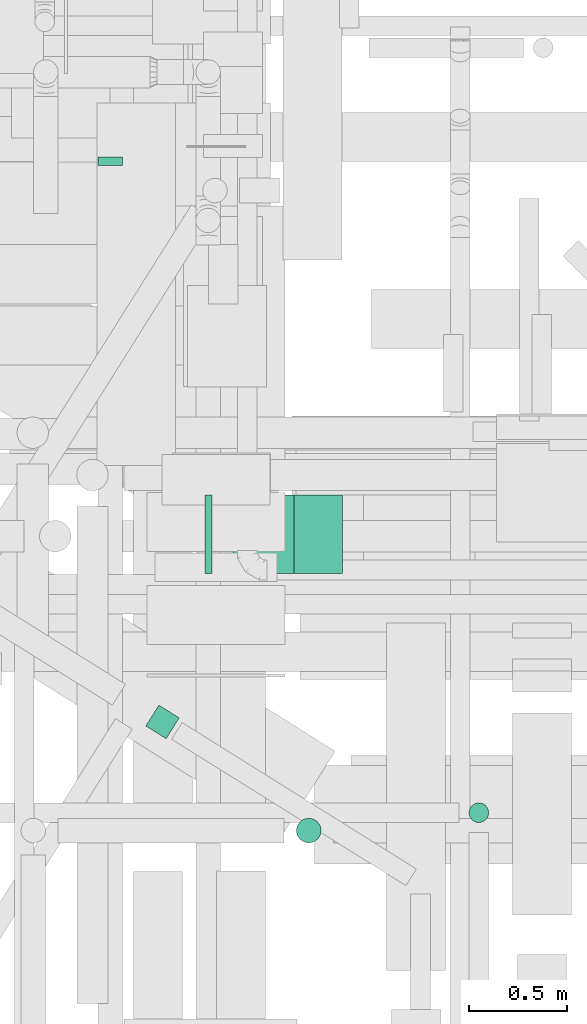
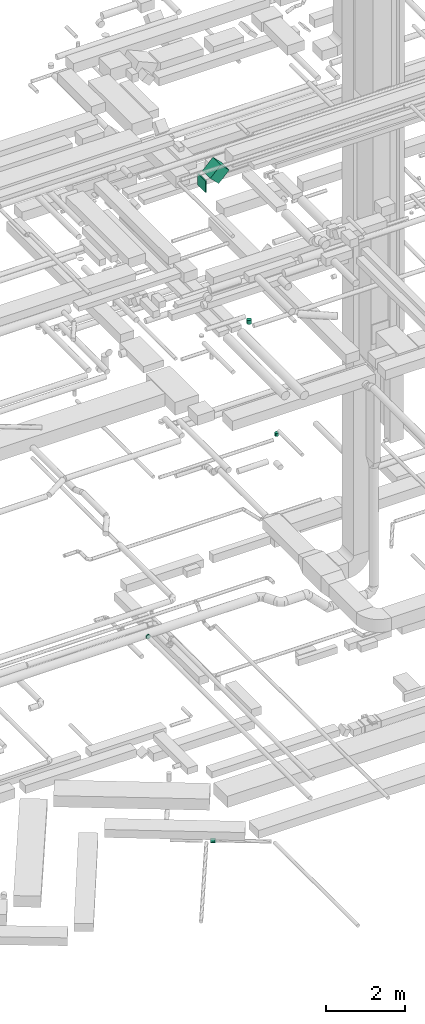
# One storey, part 103 of 337: 5 flow segments, 1 flow fitting.
"""IFC2X3 building model written with IfcOpenShell, lengths in millimetres."""

from ifc_helpers import new_model, entity, si_unit, converted_unit, derived_unit, direction, frame, origin, origin_2d_with_axis, place, context, subcontext, project, spatial, rectangle, circle, extrude, faceted_brep, source, transform, mapped, material, type_object, type_shapes, element, save


model = new_model("IFC2X3")

# Units and contexts
model_context = context("Model", 3, precision=0.01, world=origin(), true_north=direction((6.12303176911189e-17, 1.0)))
body_context = subcontext(model_context, "Body", "Model", "MODEL_VIEW")
ifc_project = project(units=[si_unit("LENGTHUNIT", "METRE", prefix="MILLI"), si_unit("AREAUNIT", "SQUARE_METRE"), si_unit("VOLUMEUNIT", "CUBIC_METRE"), converted_unit("PLANEANGLEUNIT", "DEGREE", entity("IfcRatioMeasure", 0.0174532925199433), si_unit("PLANEANGLEUNIT", "RADIAN"), dimensions=[0, 0, 0, 0, 0, 0, 0]), si_unit("MASSUNIT", "GRAM", prefix="KILO"), derived_unit("MASSDENSITYUNIT", [(si_unit("MASSUNIT", "GRAM", prefix="KILO"), 1), (si_unit("LENGTHUNIT", "METRE"), -3)]), derived_unit("MOMENTOFINERTIAUNIT", [(si_unit("LENGTHUNIT", "METRE"), 4)]), si_unit("TIMEUNIT", "SECOND"), si_unit("FREQUENCYUNIT", "HERTZ"), si_unit("THERMODYNAMICTEMPERATUREUNIT", "DEGREE_CELSIUS"), derived_unit("THERMALTRANSMITTANCEUNIT", [(si_unit("MASSUNIT", "GRAM", prefix="KILO"), 1), (si_unit("THERMODYNAMICTEMPERATUREUNIT", "KELVIN"), -1), (si_unit("TIMEUNIT", "SECOND"), -3)]), derived_unit("VOLUMETRICFLOWRATEUNIT", [(si_unit("LENGTHUNIT", "METRE"), 3), (si_unit("TIMEUNIT", "SECOND"), -1)]), derived_unit("MASSFLOWRATEUNIT", [(si_unit("MASSUNIT", "GRAM", prefix="KILO"), 1), (si_unit("TIMEUNIT", "SECOND"), -1)]), derived_unit("ROTATIONALFREQUENCYUNIT", [(si_unit("TIMEUNIT", "SECOND"), -1)]), si_unit("ELECTRICCURRENTUNIT", "AMPERE"), si_unit("ELECTRICVOLTAGEUNIT", "VOLT"), si_unit("POWERUNIT", "WATT"), si_unit("FORCEUNIT", "NEWTON", prefix="KILO"), si_unit("ILLUMINANCEUNIT", "LUX"), si_unit("LUMINOUSFLUXUNIT", "LUMEN"), si_unit("LUMINOUSINTENSITYUNIT", "CANDELA"), derived_unit("USERDEFINED", [(si_unit("MASSUNIT", "GRAM", prefix="KILO"), -1), (si_unit("LENGTHUNIT", "METRE"), -2), (si_unit("TIMEUNIT", "SECOND"), 3), (si_unit("LUMINOUSFLUXUNIT", "LUMEN"), 1)]), derived_unit("LINEARVELOCITYUNIT", [(si_unit("LENGTHUNIT", "METRE"), 1), (si_unit("TIMEUNIT", "SECOND"), -1)]), si_unit("PRESSUREUNIT", "PASCAL"), derived_unit("USERDEFINED", [(si_unit("LENGTHUNIT", "METRE"), -2), (si_unit("MASSUNIT", "GRAM", prefix="KILO"), 1), (si_unit("TIMEUNIT", "SECOND"), -2)]), derived_unit("LINEARFORCEUNIT", [(si_unit("MASSUNIT", "GRAM", prefix="KILO"), 1), (si_unit("LENGTHUNIT", "METRE"), 1), (si_unit("TIMEUNIT", "SECOND"), -2), (si_unit("LENGTHUNIT", "METRE"), -1)]), derived_unit("PLANARFORCEUNIT", [(si_unit("MASSUNIT", "GRAM", prefix="KILO"), 1), (si_unit("LENGTHUNIT", "METRE"), 1), (si_unit("TIMEUNIT", "SECOND"), -2), (si_unit("LENGTHUNIT", "METRE"), -2)])], contexts=[model_context])

# Site, building, storey
site_placement = place(None, origin())
site = spatial("IfcSite", under=ifc_project, at=site_placement, CompositionType="ELEMENT")
building_placement = place(site_placement, origin())
building = spatial("IfcBuilding", under=site, at=building_placement, CompositionType="ELEMENT")
storey_placement = place(building_placement, origin())
storey = spatial("IfcBuildingStorey", under=building, at=storey_placement, CompositionType="ELEMENT", Elevation=0.0)

# Flow segments
duct_segment_type_1 = type_object("IfcDuctSegmentType", PredefinedType="NOTDEFINED")
flow_segment_1_placement = place(storey_placement, frame((18409.23, 9525.31, 18500.0)))
element("IfcFlowSegment", 1, at=flow_segment_1_placement, inside=storey, type_object=duct_segment_type_1, context=body_context, shape_type="SweptSolid", body=[
    extrude(rectangle(XDim=35.3805922287494, YDim=400.0, at=origin_2d_with_axis()), frame((17.69, 200.0, 0.0)), (0.0, 0.0, 1.0), 349.999999999998),
])
flow_segment_2_placement = place(storey_placement, frame((18550.67, 9525.31, 18646.45)))
element("IfcFlowSegment", 2, at=flow_segment_2_placement, inside=storey, type_object=duct_segment_type_1, context=body_context, shape_type="SweptSolid", body=[
    extrude(rectangle(XDim=350.0, YDim=400.0, at=origin_2d_with_axis()), frame((123.74, 200.0, 123.74), z_axis=(0.707106781186548, 0.0, 0.707106781186548), x_axis=(-0.707106781186548, 0.0, 0.707106781186548)), (0.0, 0.0, 1.0), 437.867965643994),
])
duct_segment_type_2 = type_object("IfcDuctSegmentType", PredefinedType="NOTDEFINED")
flow_segment_3_placement = place(storey_placement, frame((18105.65, 8684.66, -1164.1)))
element("IfcFlowSegment", 3, at=flow_segment_3_placement, inside=storey, type_object=duct_segment_type_2, context=body_context, shape_type="SweptSolid", body=[
    extrude(circle(Radius=62.5, at=origin_2d_with_axis()), frame((34.72, 119.36, 64.1), z_axis=(0.848048096156444, -0.529919264233177, 0.0), x_axis=(0.529919264233177, 0.848048096156444, 0.0)), (0.0, 0.0, 1.0), 122.210613125158),
])
flow_segment_4_placement = place(storey_placement, frame((19748.51, 8258.87, 11200.0)))
element("IfcFlowSegment", 4, at=flow_segment_4_placement, inside=storey, type_object=duct_segment_type_2, context=body_context, shape_type="SweptSolid", body=[
    extrude(circle(Radius=50.0, at=origin_2d_with_axis()), frame((51.6, 51.6, 0.0), z_axis=(0.0, 0.0, 1.0), x_axis=(0.0, 1.0, 0.0)), (0.0, 0.0, 1.0), 100.000000000012),
])
flow_segment_5_placement = place(storey_placement, frame((18871.46, 8155.54, 15050.0)))
element("IfcFlowSegment", 5, at=flow_segment_5_placement, inside=storey, type_object=duct_segment_type_2, context=body_context, shape_type="SweptSolid", body=[
    extrude(circle(Radius=62.5, at=origin_2d_with_axis()), frame((64.1, 64.1, 0.0), z_axis=(0.0, 0.0, 1.0), x_axis=(0.0, 1.0, 0.0)), (0.0, 0.0, 1.0), 124.99999524356),
])

# Flow fitting
ifc_material = material()
duct_fitting_type = type_object("IfcDuctFittingType", PredefinedType="NOTDEFINED", material=ifc_material)
shared_shape = source(origin(), body_context, "Body", "Brep", [
    faceted_brep([(20.0, 16.18, -60.37), (20.0, 31.25, -54.13), (20.0, 44.19, -44.19), (20.0, 54.13, -31.25), (20.0, 60.37, -16.18), (20.0, 62.5, 0.0), (20.0, 60.37, 16.18), (20.0, 54.13, 31.25), (20.0, 44.19, 44.19), (20.0, 31.25, 54.13), (20.0, 16.18, 60.37), (20.0, 0.0, 62.5), (20.0, -16.18, 60.37), (20.0, -31.25, 54.13), (20.0, -44.19, 44.19), (20.0, -54.13, 31.25), (20.0, -60.37, 16.18), (20.0, -62.5, 0.0), (20.0, -60.37, -16.18), (20.0, -54.13, -31.25), (20.0, -44.19, -44.19), (20.0, -31.25, -54.13), (20.0, -16.18, -60.37), (20.0, 0.0, -62.5), (0.0, 0.0, 62.5), (0.0, 16.18, 60.37), (-22.84, 16.18, 60.37), (-22.84, 0.0, 62.5), (0.0, 31.25, 54.13), (-22.84, 31.25, 54.13), (0.0, 44.19, 44.19), (-22.84, 44.19, 44.19), (0.0, 54.13, 31.25), (0.0, 60.37, 16.18), (-22.84, 60.37, 16.18), (-22.84, 54.13, 31.25), (0.0, 62.5, 0.0), (-22.84, 62.5, 0.0), (0.0, 60.37, -16.18), (-22.84, 60.37, -16.18), (0.0, 54.13, -31.25), (-22.84, 54.13, -31.25), (0.0, 44.19, -44.19), (-22.84, 44.19, -44.19), (0.0, 31.25, -54.13), (0.0, 16.18, -60.37), (-22.84, 16.18, -60.37), (-22.84, 31.25, -54.13), (0.0, 0.0, -62.5), (-22.84, 0.0, -62.5), (0.0, -16.18, -60.37), (-22.84, -16.18, -60.37), (0.0, -31.25, -54.13), (-22.84, -31.25, -54.13), (0.0, -44.19, -44.19), (-22.84, -44.19, -44.19), (0.0, -54.13, -31.25), (0.0, -60.37, -16.18), (-22.84, -60.37, -16.18), (-22.84, -54.13, -31.25), (0.0, -62.5, 0.0), (-22.84, -62.5, 0.0), (0.0, -60.37, 16.18), (-22.84, -60.37, 16.18), (0.0, -54.13, 31.25), (-22.84, -54.13, 31.25), (0.0, -44.19, 44.19), (-22.84, -44.19, 44.19), (0.0, -31.25, 54.13), (0.0, -16.18, 60.37), (-22.84, -16.18, 60.37), (-22.84, -31.25, 54.13)], [[[0, 1, 2, 3, 4, 5, 6, 7, 8, 9, 10, 11, 12, 13, 14, 15, 16, 17, 18, 19, 20, 21, 22, 23]], [[24, 11, 10, 25, 26, 27]], [[25, 10, 9, 28, 29, 26]], [[28, 9, 8, 30, 31, 29]], [[32, 7, 6, 33, 34, 35]], [[33, 6, 5, 36, 37, 34]], [[30, 8, 7, 32, 35, 31]], [[36, 5, 4, 38, 39, 37]], [[38, 4, 3, 40, 41, 39]], [[40, 3, 2, 42, 43, 41]], [[44, 1, 0, 45, 46, 47]], [[45, 0, 23, 48, 49, 46]], [[42, 2, 1, 44, 47, 43]], [[48, 23, 22, 50, 51, 49]], [[50, 22, 21, 52, 53, 51]], [[52, 21, 20, 54, 55, 53]], [[56, 19, 18, 57, 58, 59]], [[57, 18, 17, 60, 61, 58]], [[54, 20, 19, 56, 59, 55]], [[60, 17, 16, 62, 63, 61]], [[62, 16, 15, 64, 65, 63]], [[64, 15, 14, 66, 67, 65]], [[68, 13, 12, 69, 70, 71]], [[69, 12, 11, 24, 27, 70]], [[66, 14, 13, 68, 71, 67]], [[49, 51, 53, 55, 59, 58, 61, 63, 65, 67, 71, 70, 27, 26, 29, 31, 35, 34, 37, 39, 41, 43, 47, 46]]]),
])
type_shapes(duct_fitting_type, [shared_shape])
flow_fitting_placement = place(storey_placement, frame((17927.44, 11619.12, 3600.0), z_axis=(0.0, 0.0, -1.0), x_axis=(0.0, -1.0, 0.0)))
element("IfcFlowFitting", 6, at=flow_fitting_placement, inside=storey, type_object=duct_fitting_type, material=ifc_material, context=body_context, shape_type="MappedRepresentation", body=[
    mapped(shared_shape, transform((0.0, 0.0, 0.0), scale=1.0)),
])

save(model, "model.ifc")
